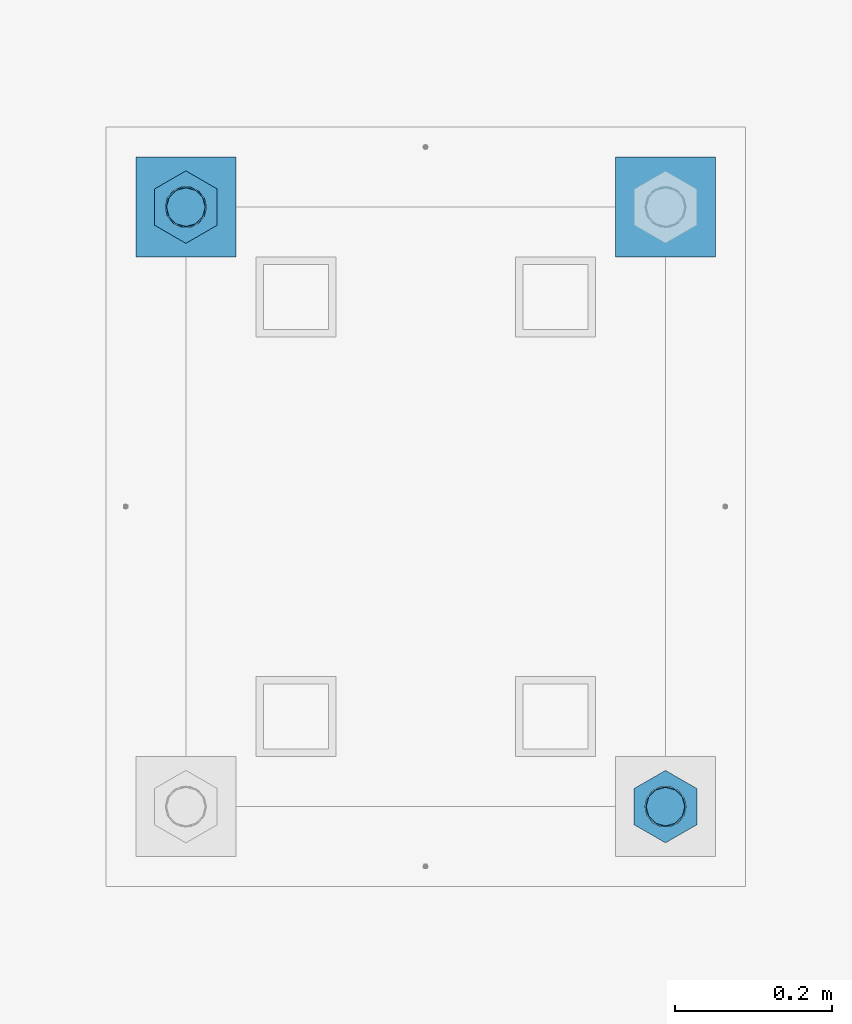
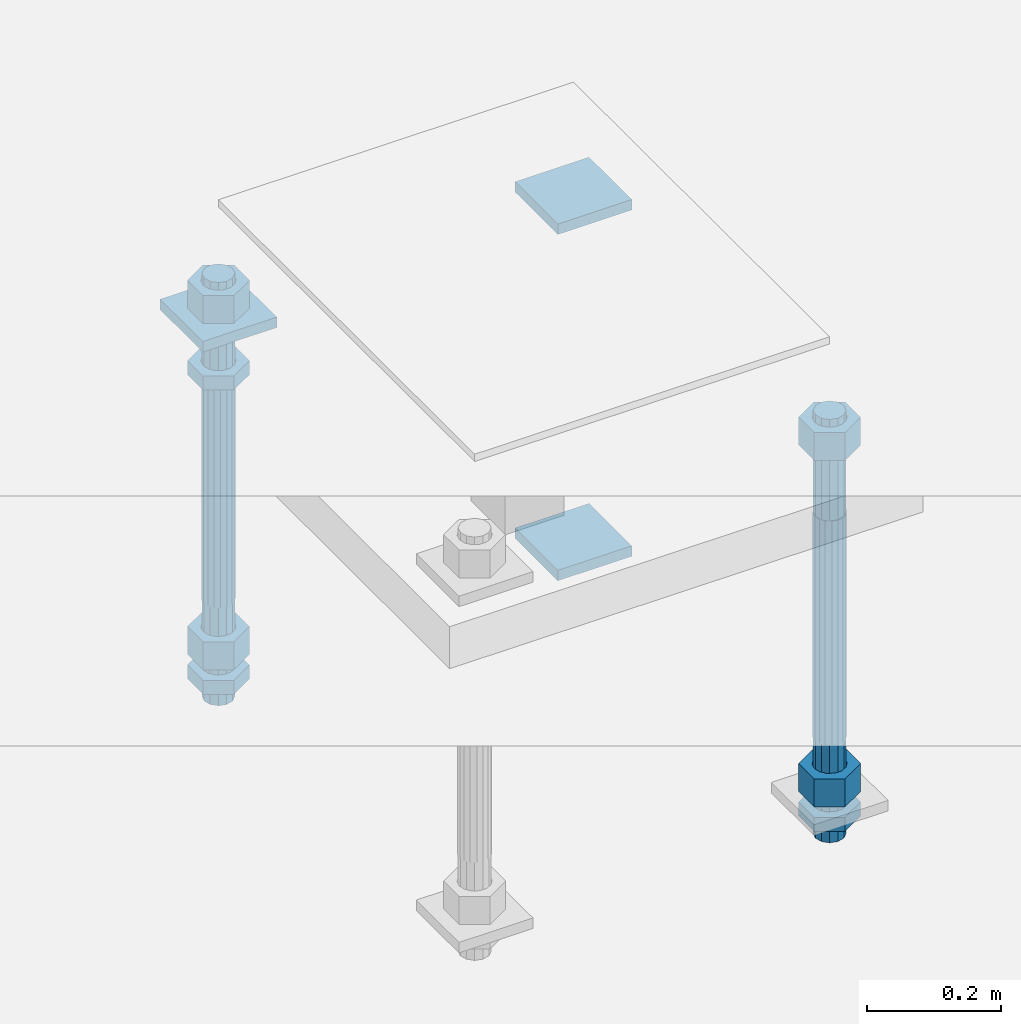
# One storey, part 2616 of 3843: 12 beams, 1 element without a shape of its own.
"""IFC2X3 building model written with IfcOpenShell, lengths in millimetres."""

from ifc_helpers import new_model, si_unit, frame, origin_with_axes, place, context, subcontext, project, spatial, faceted_brep, material, type_object, element, aggregate, save


model = new_model("IFC2X3")

# Units and contexts
model_context = context("Model", 3, precision=1e-05, world=origin_with_axes())
body_context = subcontext(model_context, "Body", "Model", "MODEL_VIEW")
ifc_project = project(units=[si_unit("LENGTHUNIT", "METRE", prefix="MILLI"), si_unit("AREAUNIT", "SQUARE_METRE"), si_unit("VOLUMEUNIT", "CUBIC_METRE"), si_unit("MASSUNIT", "GRAM", prefix="KILO"), si_unit("TIMEUNIT", "SECOND"), si_unit("PLANEANGLEUNIT", "RADIAN"), si_unit("SOLIDANGLEUNIT", "STERADIAN"), si_unit("THERMODYNAMICTEMPERATUREUNIT", "DEGREE_CELSIUS"), si_unit("LUMINOUSINTENSITYUNIT", "LUMEN")], contexts=[model_context])

# Site, building, storey
site_placement = place(None, origin_with_axes())
site = spatial("IfcSite", under=ifc_project, at=site_placement, CompositionType="ELEMENT")
building_placement = place(site_placement, origin_with_axes())
building = spatial("IfcBuilding", under=site, at=building_placement, Name="Undefined", CompositionType="ELEMENT")
storey_placement = place(building_placement, origin_with_axes())
storey = spatial("IfcBuildingStorey", under=building, at=storey_placement, Name="Undefined", CompositionType="ELEMENT", Elevation=0.0)

# Assembly, beams
assembly_placement = place(storey_placement, origin_with_axes())
assembly = element("IfcElementAssembly", 1, at=assembly_placement, inside=storey, Name="TEMPLATE", AssemblyPlace="NOTDEFINED", PredefinedType="RIGID_FRAME")
ifc_material_1 = material(Name="STEEL/A36")
beam_type_1 = type_object("IfcBeamType", PredefinedType="NOTDEFINED")
beam_1_placement = place(assembly_placement, frame((112407.7, 2032.0, 29873.575), z_axis=(0.0, 1.0, 0.0), x_axis=(-1.0, 0.0, 0.0)))
beam_1 = element("IfcBeam", 2, at=beam_1_placement, type_object=beam_type_1, material=ifc_material_1, Name="WASHER_PLATE", context=body_context, shape_type="Brep", body=[
    faceted_brep([(0.0, 9.52500000000146, -63.5), (0.0, 9.52500000000146, 63.5), (127.0, 9.52500000000146, 63.5), (127.0, 9.52500000000146, -63.5), (0.0, -9.52500000000146, 63.5), (127.0, -9.52500000000146, 63.5), (0.0, -9.52500000000146, -63.5), (127.0, -9.52500000000146, -63.5)], [[[0, 1, 2, 3]], [[1, 4, 5, 2]], [[4, 6, 7, 5]], [[6, 0, 3, 7]], [[5, 7, 3, 2]], [[6, 4, 1, 0]]]),
])
beam_2_placement = place(assembly_placement, frame((111798.099998474, 2032.0, 29873.575), z_axis=(0.0, 1.0, 0.0), x_axis=(-1.0, 0.0, 0.0)))
beam_2 = element("IfcBeam", 3, at=beam_2_placement, type_object=beam_type_1, material=ifc_material_1, Name="WASHER_PLATE", context=body_context, shape_type="Brep", body=[
    faceted_brep([(0.0, 9.52500000000146, -63.5), (0.0, 9.52500000000146, 63.5), (127.0, 9.52500000000146, 63.5), (127.0, 9.52500000000146, -63.5), (0.0, -9.52500000000146, 63.5), (127.0, -9.52500000000146, 63.5), (0.0, -9.52500000000146, -63.5), (127.0, -9.52500000000146, -63.5)], [[[0, 1, 2, 3]], [[1, 4, 5, 2]], [[4, 6, 7, 5]], [[6, 0, 3, 7]], [[5, 7, 3, 2]], [[6, 4, 1, 0]]]),
])
beam_3_placement = place(assembly_placement, frame((112407.7, 2032.00000000001, 29244.925), z_axis=(0.0, 1.0, 0.0), x_axis=(-1.0, 0.0, 0.0)))
beam_3 = element("IfcBeam", 4, at=beam_3_placement, type_object=beam_type_1, material=ifc_material_1, Name="WASHER_PLATE", context=body_context, shape_type="Brep", body=[
    faceted_brep([(0.0, 9.52500000000146, -63.5), (0.0, 9.52500000000146, 63.5), (127.0, 9.52500000000146, 63.5), (127.0, 9.52500000000146, -63.5), (0.0, -9.52500000000146, 63.5), (127.0, -9.52500000000146, 63.5), (0.0, -9.52500000000146, -63.5), (127.0, -9.52500000000146, -63.5)], [[[0, 1, 2, 3]], [[1, 4, 5, 2]], [[4, 6, 7, 5]], [[6, 0, 3, 7]], [[5, 7, 3, 2]], [[6, 4, 1, 0]]]),
])
beam_type_2 = type_object("IfcBeamType", Name="2_HALF_NUT", PredefinedType="NOTDEFINED")
beam_4_placement = place(assembly_placement, frame((111734.599998474, 2032.00000000001, 29787.85), z_axis=(-1.0, 0.0, 0.0), x_axis=(0.0, 0.0, -1.0)))
beam_4 = element("IfcBeam", 5, at=beam_4_placement, type_object=beam_type_2, material=ifc_material_1, Name="NUT", ObjectType="2_HALF_NUT", context=body_context, shape_type="Brep", body=[
    faceted_brep([(0.0, -46.0369987487793, 0.0), (0.0, -23.0184993743896, -39.869213104248), (25.4000000000015, -23.0184993743896, -39.869213104248), (25.4000000000015, -46.0369987487793, 0.0), (0.0, 23.0184993743896, -39.869213104248), (25.4000000000015, 23.0184993743896, -39.869213104248), (0.0, 46.0369987487793, 0.0), (25.4000000000015, 46.0369987487793, 0.0), (0.0, 23.0184993743896, 39.869213104248), (25.4000000000015, 23.0184993743896, 39.869213104248), (0.0, -23.0184993743896, 39.869213104248), (25.4000000000015, -23.0184993743896, 39.869213104248), (0.0, 0.0, 26.1940002441406), (0.0, 11.3650617044477, 23.5999013092805), (25.4000000000015, 11.3650617044477, 23.5999013092805), (25.4000000000015, 0.0, 26.1940002441406), (0.0, 20.4791109456419, 16.3316083006721), (25.4000000000015, 20.4791109456419, 16.3316083006721), (0.0, 25.5370200498292, 5.82867859874386), (25.4000000000015, 25.5370200498292, 5.82867859874386), (0.0, 25.5370200498292, -5.82867859874386), (25.4000000000015, 25.5370200498292, -5.82867859874386), (0.0, 20.4791109456419, -16.3316083006721), (25.4000000000015, 20.4791109456419, -16.3316083006721), (0.0, 11.3650617044477, -23.5999013092805), (25.4000000000015, 11.3650617044477, -23.5999013092805), (0.0, 0.0, -26.1940002441406), (25.4000000000015, 0.0, -26.1940002441406), (0.0, -11.3650617044477, -23.5999013092805), (25.4000000000015, -11.3650617044477, -23.5999013092805), (0.0, -20.4791109456419, -16.3316083006721), (25.4000000000015, -20.4791109456419, -16.3316083006721), (0.0, -25.5370200498292, -5.82867859874386), (25.4000000000015, -25.5370200498292, -5.82867859874386), (0.0, -25.5370200498292, 5.82867859874386), (25.4000000000015, -25.5370200498292, 5.82867859874386), (0.0, -20.4791109456419, 16.3316083006721), (25.4000000000015, -20.4791109456419, 16.3316083006721), (0.0, -11.3650617044477, 23.5999013092805), (25.4000000000015, -11.3650617044477, 23.5999013092805)], [[[0, 1, 2, 3]], [[1, 4, 5, 2]], [[4, 6, 7, 5]], [[6, 8, 9, 7]], [[8, 10, 11, 9]], [[10, 0, 3, 11]], [[12, 13, 14, 15]], [[13, 16, 17, 14]], [[16, 18, 19, 17]], [[18, 20, 21, 19]], [[20, 22, 23, 21]], [[22, 24, 25, 23]], [[24, 26, 27, 25]], [[26, 28, 29, 27]], [[28, 30, 31, 29]], [[30, 32, 33, 31]], [[32, 34, 35, 33]], [[34, 36, 37, 35]], [[36, 38, 39, 37]], [[38, 12, 15, 39]], [[5, 7, 9, 11, 3, 2], [17, 19, 21, 23, 25, 27, 29, 31, 33, 35, 37, 39, 15, 14]], [[10, 8, 6, 4, 1, 0], [38, 36, 34, 32, 30, 28, 26, 24, 22, 20, 18, 16, 13, 12]]]),
])
beam_5_placement = place(assembly_placement, frame((111734.599998474, 2032.0, 29235.4), z_axis=(-1.0, 0.0, 0.0), x_axis=(0.0, 0.0, -1.0)))
beam_5 = element("IfcBeam", 6, at=beam_5_placement, type_object=beam_type_2, material=ifc_material_1, Name="NUT", ObjectType="2_HALF_NUT", context=body_context, shape_type="Brep", body=[
    faceted_brep([(0.0, -46.0369987487793, 0.0), (0.0, -23.0184993743896, -39.869213104248), (25.4000000000015, -23.0184993743896, -39.869213104248), (25.4000000000015, -46.0369987487793, 0.0), (0.0, 23.0184993743896, -39.869213104248), (25.4000000000015, 23.0184993743896, -39.869213104248), (0.0, 46.0369987487793, 0.0), (25.4000000000015, 46.0369987487793, 0.0), (0.0, 23.0184993743896, 39.869213104248), (25.4000000000015, 23.0184993743896, 39.869213104248), (0.0, -23.0184993743896, 39.869213104248), (25.4000000000015, -23.0184993743896, 39.869213104248), (0.0, 0.0, 26.1940002441406), (0.0, 11.3650617044477, 23.5999013092805), (25.4000000000015, 11.3650617044477, 23.5999013092805), (25.4000000000015, 0.0, 26.1940002441406), (0.0, 20.4791109456419, 16.3316083006721), (25.4000000000015, 20.4791109456419, 16.3316083006721), (0.0, 25.5370200498292, 5.82867859874386), (25.4000000000015, 25.5370200498292, 5.82867859874386), (0.0, 25.5370200498292, -5.82867859874386), (25.4000000000015, 25.5370200498292, -5.82867859874386), (0.0, 20.4791109456419, -16.3316083006721), (25.4000000000015, 20.4791109456419, -16.3316083006721), (0.0, 11.3650617044477, -23.5999013092805), (25.4000000000015, 11.3650617044477, -23.5999013092805), (0.0, 0.0, -26.1940002441406), (25.4000000000015, 0.0, -26.1940002441406), (0.0, -11.3650617044477, -23.5999013092805), (25.4000000000015, -11.3650617044477, -23.5999013092805), (0.0, -20.4791109456419, -16.3316083006721), (25.4000000000015, -20.4791109456419, -16.3316083006721), (0.0, -25.5370200498292, -5.82867859874386), (25.4000000000015, -25.5370200498292, -5.82867859874386), (0.0, -25.5370200498292, 5.82867859874386), (25.4000000000015, -25.5370200498292, 5.82867859874386), (0.0, -20.4791109456419, 16.3316083006721), (25.4000000000015, -20.4791109456419, 16.3316083006721), (0.0, -11.3650617044477, 23.5999013092805), (25.4000000000015, -11.3650617044477, 23.5999013092805)], [[[0, 1, 2, 3]], [[1, 4, 5, 2]], [[4, 6, 7, 5]], [[6, 8, 9, 7]], [[8, 10, 11, 9]], [[10, 0, 3, 11]], [[12, 13, 14, 15]], [[13, 16, 17, 14]], [[16, 18, 19, 17]], [[18, 20, 21, 19]], [[20, 22, 23, 21]], [[22, 24, 25, 23]], [[24, 26, 27, 25]], [[26, 28, 29, 27]], [[28, 30, 31, 29]], [[30, 32, 33, 31]], [[32, 34, 35, 33]], [[34, 36, 37, 35]], [[36, 38, 39, 37]], [[38, 12, 15, 39]], [[5, 7, 9, 11, 3, 2], [17, 19, 21, 23, 25, 27, 29, 31, 33, 35, 37, 39, 15, 14]], [[10, 8, 6, 4, 1, 0], [38, 36, 34, 32, 30, 28, 26, 24, 22, 20, 18, 16, 13, 12]]]),
])
beam_6_placement = place(assembly_placement, frame((112344.2, 1270.0, 29235.4), z_axis=(-1.0, 0.0, 0.0), x_axis=(0.0, 0.0, -1.0)))
beam_6 = element("IfcBeam", 7, at=beam_6_placement, type_object=beam_type_2, material=ifc_material_1, Name="NUT", ObjectType="2_HALF_NUT", context=body_context, shape_type="Brep", body=[
    faceted_brep([(0.0, -46.0369987487793, 0.0), (0.0, -23.0184993743896, -39.869213104248), (25.4000000000015, -23.0184993743896, -39.869213104248), (25.4000000000015, -46.0369987487793, 0.0), (0.0, 23.0184993743896, -39.869213104248), (25.4000000000015, 23.0184993743896, -39.869213104248), (0.0, 46.0369987487793, 0.0), (25.4000000000015, 46.0369987487793, 0.0), (0.0, 23.0184993743896, 39.869213104248), (25.4000000000015, 23.0184993743896, 39.869213104248), (0.0, -23.0184993743896, 39.869213104248), (25.4000000000015, -23.0184993743896, 39.869213104248), (0.0, 0.0, 26.1940002441406), (0.0, 11.3650617044477, 23.5999013092805), (25.4000000000015, 11.3650617044477, 23.5999013092805), (25.4000000000015, 0.0, 26.1940002441406), (0.0, 20.4791109456419, 16.3316083006721), (25.4000000000015, 20.4791109456419, 16.3316083006721), (0.0, 25.5370200498292, 5.82867859874386), (25.4000000000015, 25.5370200498292, 5.82867859874386), (0.0, 25.5370200498292, -5.82867859874386), (25.4000000000015, 25.5370200498292, -5.82867859874386), (0.0, 20.4791109456419, -16.3316083006721), (25.4000000000015, 20.4791109456419, -16.3316083006721), (0.0, 11.3650617044477, -23.5999013092805), (25.4000000000015, 11.3650617044477, -23.5999013092805), (0.0, 0.0, -26.1940002441406), (25.4000000000015, 0.0, -26.1940002441406), (0.0, -11.3650617044477, -23.5999013092805), (25.4000000000015, -11.3650617044477, -23.5999013092805), (0.0, -20.4791109456419, -16.3316083006721), (25.4000000000015, -20.4791109456419, -16.3316083006721), (0.0, -25.5370200498292, -5.82867859874386), (25.4000000000015, -25.5370200498292, -5.82867859874386), (0.0, -25.5370200498292, 5.82867859874386), (25.4000000000015, -25.5370200498292, 5.82867859874386), (0.0, -20.4791109456419, 16.3316083006721), (25.4000000000015, -20.4791109456419, 16.3316083006721), (0.0, -11.3650617044477, 23.5999013092805), (25.4000000000015, -11.3650617044477, 23.5999013092805)], [[[0, 1, 2, 3]], [[1, 4, 5, 2]], [[4, 6, 7, 5]], [[6, 8, 9, 7]], [[8, 10, 11, 9]], [[10, 0, 3, 11]], [[12, 13, 14, 15]], [[13, 16, 17, 14]], [[16, 18, 19, 17]], [[18, 20, 21, 19]], [[20, 22, 23, 21]], [[22, 24, 25, 23]], [[24, 26, 27, 25]], [[26, 28, 29, 27]], [[28, 30, 31, 29]], [[30, 32, 33, 31]], [[32, 34, 35, 33]], [[34, 36, 37, 35]], [[36, 38, 39, 37]], [[38, 12, 15, 39]], [[5, 7, 9, 11, 3, 2], [17, 19, 21, 23, 25, 27, 29, 31, 33, 35, 37, 39, 15, 14]], [[10, 8, 6, 4, 1, 0], [38, 36, 34, 32, 30, 28, 26, 24, 22, 20, 18, 16, 13, 12]]]),
])
beam_type_3 = type_object("IfcBeamType", Name="2_HEAVY_HEX_NUT", PredefinedType="NOTDEFINED")
beam_7_placement = place(assembly_placement, frame((111734.599998474, 2032.00000000001, 29933.9), z_axis=(-1.0, 0.0, 0.0), x_axis=(0.0, 0.0, -1.0)))
beam_7 = element("IfcBeam", 8, at=beam_7_placement, type_object=beam_type_3, material=ifc_material_1, Name="NUT", ObjectType="2_HEAVY_HEX_NUT", context=body_context, shape_type="Brep", body=[
    faceted_brep([(0.0, -46.0369987487793, 0.0), (0.0, -23.0184993743896, -39.869213104248), (50.7999999999993, -23.0184993743896, -39.869213104248), (50.7999999999993, -46.0369987487793, 0.0), (0.0, 23.0184993743896, -39.869213104248), (50.7999999999993, 23.0184993743896, -39.869213104248), (0.0, 46.0369987487793, 0.0), (50.7999999999993, 46.0369987487793, 0.0), (0.0, 23.0184993743896, 39.869213104248), (50.7999999999993, 23.0184993743896, 39.869213104248), (0.0, -23.0184993743896, 39.869213104248), (50.7999999999993, -23.0184993743896, 39.869213104248), (0.0, 0.0, 26.1940002441406), (0.0, 11.3650617044477, 23.5999013092805), (50.7999999999993, 11.3650617044477, 23.5999013092805), (50.7999999999993, 0.0, 26.1940002441406), (0.0, 20.4791109456419, 16.3316083006721), (50.7999999999993, 20.4791109456419, 16.3316083006721), (0.0, 25.5370200498292, 5.82867859874386), (50.7999999999993, 25.5370200498292, 5.82867859874386), (0.0, 25.5370200498292, -5.82867859874386), (50.7999999999993, 25.5370200498292, -5.82867859874386), (0.0, 20.4791109456419, -16.3316083006721), (50.7999999999993, 20.4791109456419, -16.3316083006721), (0.0, 11.3650617044477, -23.5999013092805), (50.7999999999993, 11.3650617044477, -23.5999013092805), (0.0, 0.0, -26.1940002441406), (50.7999999999993, 0.0, -26.1940002441406), (0.0, -11.3650617044477, -23.5999013092805), (50.7999999999993, -11.3650617044477, -23.5999013092805), (0.0, -20.4791109456419, -16.3316083006721), (50.7999999999993, -20.4791109456419, -16.3316083006721), (0.0, -25.5370200498292, -5.82867859874386), (50.7999999999993, -25.5370200498292, -5.82867859874386), (0.0, -25.5370200498292, 5.82867859874386), (50.7999999999993, -25.5370200498292, 5.82867859874386), (0.0, -20.4791109456419, 16.3316083006721), (50.7999999999993, -20.4791109456419, 16.3316083006721), (0.0, -11.3650617044477, 23.5999013092805), (50.7999999999993, -11.3650617044477, 23.5999013092805)], [[[0, 1, 2, 3]], [[1, 4, 5, 2]], [[4, 6, 7, 5]], [[6, 8, 9, 7]], [[8, 10, 11, 9]], [[10, 0, 3, 11]], [[12, 13, 14, 15]], [[13, 16, 17, 14]], [[16, 18, 19, 17]], [[18, 20, 21, 19]], [[20, 22, 23, 21]], [[22, 24, 25, 23]], [[24, 26, 27, 25]], [[26, 28, 29, 27]], [[28, 30, 31, 29]], [[30, 32, 33, 31]], [[32, 34, 35, 33]], [[34, 36, 37, 35]], [[36, 38, 39, 37]], [[38, 12, 15, 39]], [[5, 7, 9, 11, 3, 2], [17, 19, 21, 23, 25, 27, 29, 31, 33, 35, 37, 39, 15, 14]], [[10, 8, 6, 4, 1, 0], [38, 36, 34, 32, 30, 28, 26, 24, 22, 20, 18, 16, 13, 12]]]),
])
beam_8_placement = place(assembly_placement, frame((111734.599998474, 2032.00000000001, 29305.25), z_axis=(-1.0, 0.0, 0.0), x_axis=(0.0, 0.0, -1.0)))
beam_8 = element("IfcBeam", 9, at=beam_8_placement, type_object=beam_type_3, material=ifc_material_1, Name="NUT", ObjectType="2_HEAVY_HEX_NUT", context=body_context, shape_type="Brep", body=[
    faceted_brep([(0.0, -46.0369987487793, 0.0), (0.0, -23.0184993743896, -39.869213104248), (50.7999999999993, -23.0184993743896, -39.869213104248), (50.7999999999993, -46.0369987487793, 0.0), (0.0, 23.0184993743896, -39.869213104248), (50.7999999999993, 23.0184993743896, -39.869213104248), (0.0, 46.0369987487793, 0.0), (50.7999999999993, 46.0369987487793, 0.0), (0.0, 23.0184993743896, 39.869213104248), (50.7999999999993, 23.0184993743896, 39.869213104248), (0.0, -23.0184993743896, 39.869213104248), (50.7999999999993, -23.0184993743896, 39.869213104248), (0.0, 0.0, 26.1940002441406), (0.0, 11.3650617044477, 23.5999013092805), (50.7999999999993, 11.3650617044477, 23.5999013092805), (50.7999999999993, 0.0, 26.1940002441406), (0.0, 20.4791109456419, 16.3316083006721), (50.7999999999993, 20.4791109456419, 16.3316083006721), (0.0, 25.5370200498292, 5.82867859874386), (50.7999999999993, 25.5370200498292, 5.82867859874386), (0.0, 25.5370200498292, -5.82867859874386), (50.7999999999993, 25.5370200498292, -5.82867859874386), (0.0, 20.4791109456419, -16.3316083006721), (50.7999999999993, 20.4791109456419, -16.3316083006721), (0.0, 11.3650617044477, -23.5999013092805), (50.7999999999993, 11.3650617044477, -23.5999013092805), (0.0, 0.0, -26.1940002441406), (50.7999999999993, 0.0, -26.1940002441406), (0.0, -11.3650617044477, -23.5999013092805), (50.7999999999993, -11.3650617044477, -23.5999013092805), (0.0, -20.4791109456419, -16.3316083006721), (50.7999999999993, -20.4791109456419, -16.3316083006721), (0.0, -25.5370200498292, -5.82867859874386), (50.7999999999993, -25.5370200498292, -5.82867859874386), (0.0, -25.5370200498292, 5.82867859874386), (50.7999999999993, -25.5370200498292, 5.82867859874386), (0.0, -20.4791109456419, 16.3316083006721), (50.7999999999993, -20.4791109456419, 16.3316083006721), (0.0, -11.3650617044477, 23.5999013092805), (50.7999999999993, -11.3650617044477, 23.5999013092805)], [[[0, 1, 2, 3]], [[1, 4, 5, 2]], [[4, 6, 7, 5]], [[6, 8, 9, 7]], [[8, 10, 11, 9]], [[10, 0, 3, 11]], [[12, 13, 14, 15]], [[13, 16, 17, 14]], [[16, 18, 19, 17]], [[18, 20, 21, 19]], [[20, 22, 23, 21]], [[22, 24, 25, 23]], [[24, 26, 27, 25]], [[26, 28, 29, 27]], [[28, 30, 31, 29]], [[30, 32, 33, 31]], [[32, 34, 35, 33]], [[34, 36, 37, 35]], [[36, 38, 39, 37]], [[38, 12, 15, 39]], [[5, 7, 9, 11, 3, 2], [17, 19, 21, 23, 25, 27, 29, 31, 33, 35, 37, 39, 15, 14]], [[10, 8, 6, 4, 1, 0], [38, 36, 34, 32, 30, 28, 26, 24, 22, 20, 18, 16, 13, 12]]]),
])
beam_9_placement = place(assembly_placement, frame((112344.2, 1270.00000000001, 29933.9), z_axis=(-1.0, 0.0, 0.0), x_axis=(0.0, 0.0, -1.0)))
beam_9 = element("IfcBeam", 10, at=beam_9_placement, type_object=beam_type_3, material=ifc_material_1, Name="NUT", ObjectType="2_HEAVY_HEX_NUT", context=body_context, shape_type="Brep", body=[
    faceted_brep([(0.0, -46.0369987487793, 0.0), (0.0, -23.0184993743896, -39.869213104248), (50.7999999999993, -23.0184993743896, -39.869213104248), (50.7999999999993, -46.0369987487793, 0.0), (0.0, 23.0184993743896, -39.869213104248), (50.7999999999993, 23.0184993743896, -39.869213104248), (0.0, 46.0369987487793, 0.0), (50.7999999999993, 46.0369987487793, 0.0), (0.0, 23.0184993743896, 39.869213104248), (50.7999999999993, 23.0184993743896, 39.869213104248), (0.0, -23.0184993743896, 39.869213104248), (50.7999999999993, -23.0184993743896, 39.869213104248), (0.0, 0.0, 26.1940002441406), (0.0, 11.3650617044477, 23.5999013092805), (50.7999999999993, 11.3650617044477, 23.5999013092805), (50.7999999999993, 0.0, 26.1940002441406), (0.0, 20.4791109456419, 16.3316083006721), (50.7999999999993, 20.4791109456419, 16.3316083006721), (0.0, 25.5370200498292, 5.82867859874386), (50.7999999999993, 25.5370200498292, 5.82867859874386), (0.0, 25.5370200498292, -5.82867859874386), (50.7999999999993, 25.5370200498292, -5.82867859874386), (0.0, 20.4791109456419, -16.3316083006721), (50.7999999999993, 20.4791109456419, -16.3316083006721), (0.0, 11.3650617044477, -23.5999013092805), (50.7999999999993, 11.3650617044477, -23.5999013092805), (0.0, 0.0, -26.1940002441406), (50.7999999999993, 0.0, -26.1940002441406), (0.0, -11.3650617044477, -23.5999013092805), (50.7999999999993, -11.3650617044477, -23.5999013092805), (0.0, -20.4791109456419, -16.3316083006721), (50.7999999999993, -20.4791109456419, -16.3316083006721), (0.0, -25.5370200498292, -5.82867859874386), (50.7999999999993, -25.5370200498292, -5.82867859874386), (0.0, -25.5370200498292, 5.82867859874386), (50.7999999999993, -25.5370200498292, 5.82867859874386), (0.0, -20.4791109456419, 16.3316083006721), (50.7999999999993, -20.4791109456419, 16.3316083006721), (0.0, -11.3650617044477, 23.5999013092805), (50.7999999999993, -11.3650617044477, 23.5999013092805)], [[[0, 1, 2, 3]], [[1, 4, 5, 2]], [[4, 6, 7, 5]], [[6, 8, 9, 7]], [[8, 10, 11, 9]], [[10, 0, 3, 11]], [[12, 13, 14, 15]], [[13, 16, 17, 14]], [[16, 18, 19, 17]], [[18, 20, 21, 19]], [[20, 22, 23, 21]], [[22, 24, 25, 23]], [[24, 26, 27, 25]], [[26, 28, 29, 27]], [[28, 30, 31, 29]], [[30, 32, 33, 31]], [[32, 34, 35, 33]], [[34, 36, 37, 35]], [[36, 38, 39, 37]], [[38, 12, 15, 39]], [[5, 7, 9, 11, 3, 2], [17, 19, 21, 23, 25, 27, 29, 31, 33, 35, 37, 39, 15, 14]], [[10, 8, 6, 4, 1, 0], [38, 36, 34, 32, 30, 28, 26, 24, 22, 20, 18, 16, 13, 12]]]),
])
beam_10_placement = place(assembly_placement, frame((112344.2, 1270.00000000001, 29305.25), z_axis=(-1.0, 0.0, 0.0), x_axis=(0.0, 0.0, -1.0)))
beam_10 = element("IfcBeam", 11, at=beam_10_placement, type_object=beam_type_3, material=ifc_material_1, Name="NUT", ObjectType="2_HEAVY_HEX_NUT", context=body_context, shape_type="Brep", body=[
    faceted_brep([(0.0, -46.0369987487793, 0.0), (0.0, -23.0184993743896, -39.869213104248), (50.7999999999993, -23.0184993743896, -39.869213104248), (50.7999999999993, -46.0369987487793, 0.0), (0.0, 23.0184993743896, -39.869213104248), (50.7999999999993, 23.0184993743896, -39.869213104248), (0.0, 46.0369987487793, 0.0), (50.7999999999993, 46.0369987487793, 0.0), (0.0, 23.0184993743896, 39.869213104248), (50.7999999999993, 23.0184993743896, 39.869213104248), (0.0, -23.0184993743896, 39.869213104248), (50.7999999999993, -23.0184993743896, 39.869213104248), (0.0, 0.0, 26.1940002441406), (0.0, 11.3650617044477, 23.5999013092805), (50.7999999999993, 11.3650617044477, 23.5999013092805), (50.7999999999993, 0.0, 26.1940002441406), (0.0, 20.4791109456419, 16.3316083006721), (50.7999999999993, 20.4791109456419, 16.3316083006721), (0.0, 25.5370200498292, 5.82867859874386), (50.7999999999993, 25.5370200498292, 5.82867859874386), (0.0, 25.5370200498292, -5.82867859874386), (50.7999999999993, 25.5370200498292, -5.82867859874386), (0.0, 20.4791109456419, -16.3316083006721), (50.7999999999993, 20.4791109456419, -16.3316083006721), (0.0, 11.3650617044477, -23.5999013092805), (50.7999999999993, 11.3650617044477, -23.5999013092805), (0.0, 0.0, -26.1940002441406), (50.7999999999993, 0.0, -26.1940002441406), (0.0, -11.3650617044477, -23.5999013092805), (50.7999999999993, -11.3650617044477, -23.5999013092805), (0.0, -20.4791109456419, -16.3316083006721), (50.7999999999993, -20.4791109456419, -16.3316083006721), (0.0, -25.5370200498292, -5.82867859874386), (50.7999999999993, -25.5370200498292, -5.82867859874386), (0.0, -25.5370200498292, 5.82867859874386), (50.7999999999993, -25.5370200498292, 5.82867859874386), (0.0, -20.4791109456419, 16.3316083006721), (50.7999999999993, -20.4791109456419, 16.3316083006721), (0.0, -11.3650617044477, 23.5999013092805), (50.7999999999993, -11.3650617044477, 23.5999013092805)], [[[0, 1, 2, 3]], [[1, 4, 5, 2]], [[4, 6, 7, 5]], [[6, 8, 9, 7]], [[8, 10, 11, 9]], [[10, 0, 3, 11]], [[12, 13, 14, 15]], [[13, 16, 17, 14]], [[16, 18, 19, 17]], [[18, 20, 21, 19]], [[20, 22, 23, 21]], [[22, 24, 25, 23]], [[24, 26, 27, 25]], [[26, 28, 29, 27]], [[28, 30, 31, 29]], [[30, 32, 33, 31]], [[32, 34, 35, 33]], [[34, 36, 37, 35]], [[36, 38, 39, 37]], [[38, 12, 15, 39]], [[5, 7, 9, 11, 3, 2], [17, 19, 21, 23, 25, 27, 29, 31, 33, 35, 37, 39, 15, 14]], [[10, 8, 6, 4, 1, 0], [38, 36, 34, 32, 30, 28, 26, 24, 22, 20, 18, 16, 13, 12]]]),
])
ifc_material_2 = material()
beam_type_4 = type_object("IfcBeamType", PredefinedType="NOTDEFINED")
beam_11_placement = place(assembly_placement, frame((111734.599998474, 2032.00000000001, 29762.45), z_axis=(-1.0, 0.0, 0.0), x_axis=(0.0, 0.0, -1.0)))
beam_11 = element("IfcBeam", 12, at=beam_11_placement, type_object=beam_type_4, material=ifc_material_2, Name="ANCHOR_ROD", context=body_context, shape_type="Brep", body=[
    faceted_brep([(-184.150000000001, -21.217622392709, 12.25), (-184.150000000001, -12.2499999999854, 21.2176223927163), (-184.150000000001, 1.45519152283669e-11, 24.5), (-184.150000000001, 12.2500000000146, 21.2176223927163), (-184.150000000001, 21.2176223927381, 12.25), (-184.150000000001, 24.5000000000146, 0.0), (-184.150000000001, 21.2176223927381, -12.25), (-184.150000000001, 12.2500000000146, -21.2176223927163), (-184.150000000001, 1.45519152283669e-11, -24.5), (-184.150000000001, -12.2499999999854, -21.2176223927163), (-184.150000000001, -21.217622392709, -12.25), (-184.150000000001, -24.4999999999854, 0.0), (0.0, 24.5000000000146, 0.0), (0.0, 21.2176223927381, -12.25), (0.0, 12.2500000000146, -21.2176223927163), (0.0, 1.45519152283669e-11, -24.5), (0.0, -12.2499999999854, -21.2176223927163), (0.0, -21.217622392709, -12.25), (0.0, -24.4999999999854, 0.0), (0.0, -21.217622392709, 12.25), (0.0, -12.2499999999854, 21.2176223927163), (0.0, 1.45519152283669e-11, 24.5), (0.0, 12.2500000000146, 21.2176223927163), (0.0, 21.2176223927381, 12.25), (0.0, -23.4665401257807, 9.72015918207035), (0.0, -17.9605122421344, 17.9605122421417), (0.0, -9.72015918207762, 23.466540125788), (0.0, 0.0, 25.4000000000015), (0.0, 9.72015918207762, 23.466540125788), (0.0, 17.9605122421344, 17.9605122421417), (0.0, 23.4665401257807, 9.72015918207035), (0.0, 25.3999996185303, 0.0), (0.0, 23.4665401257807, -9.72015918207035), (0.0, 17.9605122421344, -17.9605122421417), (0.0, 9.72015918207762, -23.466540125788), (0.0, 0.0, -25.4000000000015), (0.0, -9.72015918207762, -23.466540125788), (0.0, -17.9605122421344, -17.9605122421417), (0.0, -23.4665401257807, -9.72015918207035), (0.0, -25.3999996185303, 0.0), (406.399999999998, -25.3999999999942, 0.0), (406.399999999998, -23.4665401257807, 9.72015918207035), (406.399999999998, -17.9605122421344, 17.9605122421417), (406.399999999998, -9.72015918207762, 23.466540125788), (406.399999999998, 0.0, 25.4000000000015), (406.399999999998, 9.72015918207762, 23.466540125788), (406.399999999998, 17.9605122421344, 17.9605122421417), (406.399999999998, 23.4665401257807, 9.72015918207035), (406.399999999998, 25.3999999999942, 0.0), (406.399999999998, 23.4665401257807, -9.72015918207035), (406.399999999998, 17.9605122421344, -17.9605122421417), (406.399999999998, 9.72015918207762, -23.466540125788), (406.399999999998, 0.0, -25.4000000000015), (406.399999999998, -9.72015918207762, -23.466540125788), (406.399999999998, -17.9605122421344, -17.9605122421417), (406.399999999998, -23.4665401257807, -9.72015918207035), (406.399999999998, -12.2499999999854, 21.2176223927163), (406.399999999998, 1.45519152283669e-11, 24.5), (406.399999999998, 12.2500000000146, 21.2176223927163), (406.399999999998, 21.2176223927381, 12.25), (406.399999999998, 24.5000000000146, 0.0), (406.399999999998, 21.2176223927381, -12.25), (406.399999999998, 12.2500000000146, -21.2176223927163), (406.399999999998, 1.45519152283669e-11, -24.5), (406.399999999998, -12.2499999999854, -21.2176223927163), (406.399999999998, -21.217622392709, -12.25), (406.399999999998, -24.4999999999854, 0.0), (406.399999999998, -21.217622392709, 12.25), (584.200000000001, -12.2499999999854, -21.2176223927163), (584.200000000001, 1.45519152283669e-11, -24.5), (584.200000000001, 12.2500000000146, -21.2176223927163), (584.200000000001, 21.2176223927381, -12.25), (584.200000000001, 24.5000000000146, 0.0), (584.200000000001, 21.2176223927381, 12.25), (584.200000000001, 12.2500000000146, 21.2176223927163), (584.200000000001, 1.45519152283669e-11, 24.5), (584.200000000001, -12.2499999999854, 21.2176223927163), (584.200000000001, -21.217622392709, 12.25), (584.200000000001, -24.4999999999854, 0.0), (584.200000000001, -21.217622392709, -12.25)], [[[0, 1, 2, 3, 4, 5, 6, 7, 8, 9, 10, 11]], [[6, 5, 12, 13]], [[7, 6, 13, 14]], [[8, 7, 14, 15]], [[9, 8, 15, 16]], [[10, 9, 16, 17]], [[11, 10, 17, 18]], [[0, 11, 18, 19]], [[1, 0, 19, 20]], [[2, 1, 20, 21]], [[3, 2, 21, 22]], [[4, 3, 22, 23]], [[5, 4, 23, 12]], [[24, 25, 26, 27, 28, 29, 30, 31, 32, 33, 34, 35, 36, 37, 38, 39], [22, 21, 20, 19, 18, 17, 16, 15, 14, 13, 12, 23]], [[24, 39, 40, 41]], [[25, 24, 41, 42]], [[26, 25, 42, 43]], [[27, 26, 43, 44]], [[28, 27, 44, 45]], [[29, 28, 45, 46]], [[30, 29, 46, 47]], [[31, 30, 47, 48]], [[32, 31, 48, 49]], [[33, 32, 49, 50]], [[34, 33, 50, 51]], [[35, 34, 51, 52]], [[36, 35, 52, 53]], [[37, 36, 53, 54]], [[38, 37, 54, 55]], [[39, 38, 55, 40]], [[54, 53, 52, 51, 50, 49, 48, 47, 46, 45, 44, 43, 42, 41, 40, 55], [56, 57, 58, 59, 60, 61, 62, 63, 64, 65, 66, 67]], [[68, 69, 70, 71, 72, 73, 74, 75, 76, 77, 78, 79]], [[76, 75, 57, 56]], [[77, 76, 56, 67]], [[78, 77, 67, 66]], [[79, 78, 66, 65]], [[68, 79, 65, 64]], [[69, 68, 64, 63]], [[70, 69, 63, 62]], [[71, 70, 62, 61]], [[72, 71, 61, 60]], [[73, 72, 60, 59]], [[74, 73, 59, 58]], [[75, 74, 58, 57]]]),
])
beam_12_placement = place(assembly_placement, frame((112344.2, 1270.00000000001, 29762.45), z_axis=(-1.0, 0.0, 0.0), x_axis=(0.0, 0.0, -1.0)))
beam_12 = element("IfcBeam", 13, at=beam_12_placement, type_object=beam_type_4, material=ifc_material_2, Name="ANCHOR_ROD", context=body_context, shape_type="Brep", body=[
    faceted_brep([(-184.150000000001, -21.217622392709, 12.25), (-184.150000000001, -12.2499999999854, 21.2176223927163), (-184.150000000001, 1.45519152283669e-11, 24.5), (-184.150000000001, 12.2500000000146, 21.2176223927163), (-184.150000000001, 21.2176223927381, 12.25), (-184.150000000001, 24.5000000000146, 0.0), (-184.150000000001, 21.2176223927381, -12.25), (-184.150000000001, 12.2500000000146, -21.2176223927163), (-184.150000000001, 1.45519152283669e-11, -24.5), (-184.150000000001, -12.2499999999854, -21.2176223927163), (-184.150000000001, -21.217622392709, -12.25), (-184.150000000001, -24.4999999999854, 0.0), (0.0, 24.5000000000146, 0.0), (0.0, 21.2176223927381, -12.25), (0.0, 12.2500000000146, -21.2176223927163), (0.0, 1.45519152283669e-11, -24.5), (0.0, -12.2499999999854, -21.2176223927163), (0.0, -21.217622392709, -12.25), (0.0, -24.4999999999854, 0.0), (0.0, -21.217622392709, 12.25), (0.0, -12.2499999999854, 21.2176223927163), (0.0, 1.45519152283669e-11, 24.5), (0.0, 12.2500000000146, 21.2176223927163), (0.0, 21.2176223927381, 12.25), (0.0, -23.4665401257807, 9.72015918207035), (0.0, -17.9605122421344, 17.9605122421417), (0.0, -9.72015918207762, 23.466540125788), (0.0, 0.0, 25.4000000000015), (0.0, 9.72015918207762, 23.466540125788), (0.0, 17.9605122421344, 17.9605122421417), (0.0, 23.4665401257807, 9.72015918207035), (0.0, 25.3999996185303, 0.0), (0.0, 23.4665401257807, -9.72015918207035), (0.0, 17.9605122421344, -17.9605122421417), (0.0, 9.72015918207762, -23.466540125788), (0.0, 0.0, -25.4000000000015), (0.0, -9.72015918207762, -23.466540125788), (0.0, -17.9605122421344, -17.9605122421417), (0.0, -23.4665401257807, -9.72015918207035), (0.0, -25.3999996185303, 0.0), (406.399999999998, -25.3999999999942, 0.0), (406.399999999998, -23.4665401257807, 9.72015918207035), (406.399999999998, -17.9605122421344, 17.9605122421417), (406.399999999998, -9.72015918207762, 23.466540125788), (406.399999999998, 0.0, 25.4000000000015), (406.399999999998, 9.72015918207762, 23.466540125788), (406.399999999998, 17.9605122421344, 17.9605122421417), (406.399999999998, 23.4665401257807, 9.72015918207035), (406.399999999998, 25.3999999999942, 0.0), (406.399999999998, 23.4665401257807, -9.72015918207035), (406.399999999998, 17.9605122421344, -17.9605122421417), (406.399999999998, 9.72015918207762, -23.466540125788), (406.399999999998, 0.0, -25.4000000000015), (406.399999999998, -9.72015918207762, -23.466540125788), (406.399999999998, -17.9605122421344, -17.9605122421417), (406.399999999998, -23.4665401257807, -9.72015918207035), (406.399999999998, -12.2499999999854, 21.2176223927163), (406.399999999998, 1.45519152283669e-11, 24.5), (406.399999999998, 12.2500000000146, 21.2176223927163), (406.399999999998, 21.2176223927381, 12.25), (406.399999999998, 24.5000000000146, 0.0), (406.399999999998, 21.2176223927381, -12.25), (406.399999999998, 12.2500000000146, -21.2176223927163), (406.399999999998, 1.45519152283669e-11, -24.5), (406.399999999998, -12.2499999999854, -21.2176223927163), (406.399999999998, -21.217622392709, -12.25), (406.399999999998, -24.4999999999854, 0.0), (406.399999999998, -21.217622392709, 12.25), (584.200000000001, -12.2499999999854, -21.2176223927163), (584.200000000001, 1.45519152283669e-11, -24.5), (584.200000000001, 12.2500000000146, -21.2176223927163), (584.200000000001, 21.2176223927381, -12.25), (584.200000000001, 24.5000000000146, 0.0), (584.200000000001, 21.2176223927381, 12.25), (584.200000000001, 12.2500000000146, 21.2176223927163), (584.200000000001, 1.45519152283669e-11, 24.5), (584.200000000001, -12.2499999999854, 21.2176223927163), (584.200000000001, -21.217622392709, 12.25), (584.200000000001, -24.4999999999854, 0.0), (584.200000000001, -21.217622392709, -12.25)], [[[0, 1, 2, 3, 4, 5, 6, 7, 8, 9, 10, 11]], [[6, 5, 12, 13]], [[7, 6, 13, 14]], [[8, 7, 14, 15]], [[9, 8, 15, 16]], [[10, 9, 16, 17]], [[11, 10, 17, 18]], [[0, 11, 18, 19]], [[1, 0, 19, 20]], [[2, 1, 20, 21]], [[3, 2, 21, 22]], [[4, 3, 22, 23]], [[5, 4, 23, 12]], [[24, 25, 26, 27, 28, 29, 30, 31, 32, 33, 34, 35, 36, 37, 38, 39], [22, 21, 20, 19, 18, 17, 16, 15, 14, 13, 12, 23]], [[24, 39, 40, 41]], [[25, 24, 41, 42]], [[26, 25, 42, 43]], [[27, 26, 43, 44]], [[28, 27, 44, 45]], [[29, 28, 45, 46]], [[30, 29, 46, 47]], [[31, 30, 47, 48]], [[32, 31, 48, 49]], [[33, 32, 49, 50]], [[34, 33, 50, 51]], [[35, 34, 51, 52]], [[36, 35, 52, 53]], [[37, 36, 53, 54]], [[38, 37, 54, 55]], [[39, 38, 55, 40]], [[54, 53, 52, 51, 50, 49, 48, 47, 46, 45, 44, 43, 42, 41, 40, 55], [56, 57, 58, 59, 60, 61, 62, 63, 64, 65, 66, 67]], [[68, 69, 70, 71, 72, 73, 74, 75, 76, 77, 78, 79]], [[76, 75, 57, 56]], [[77, 76, 56, 67]], [[78, 77, 67, 66]], [[79, 78, 66, 65]], [[68, 79, 65, 64]], [[69, 68, 64, 63]], [[70, 69, 63, 62]], [[71, 70, 62, 61]], [[72, 71, 61, 60]], [[73, 72, 60, 59]], [[74, 73, 59, 58]], [[75, 74, 58, 57]]]),
])
aggregate(assembly, [beam_1, beam_2, beam_4, beam_7, beam_8, beam_5, beam_11, beam_9, beam_10, beam_6, beam_12, beam_3])

save(model, "model.ifc")
